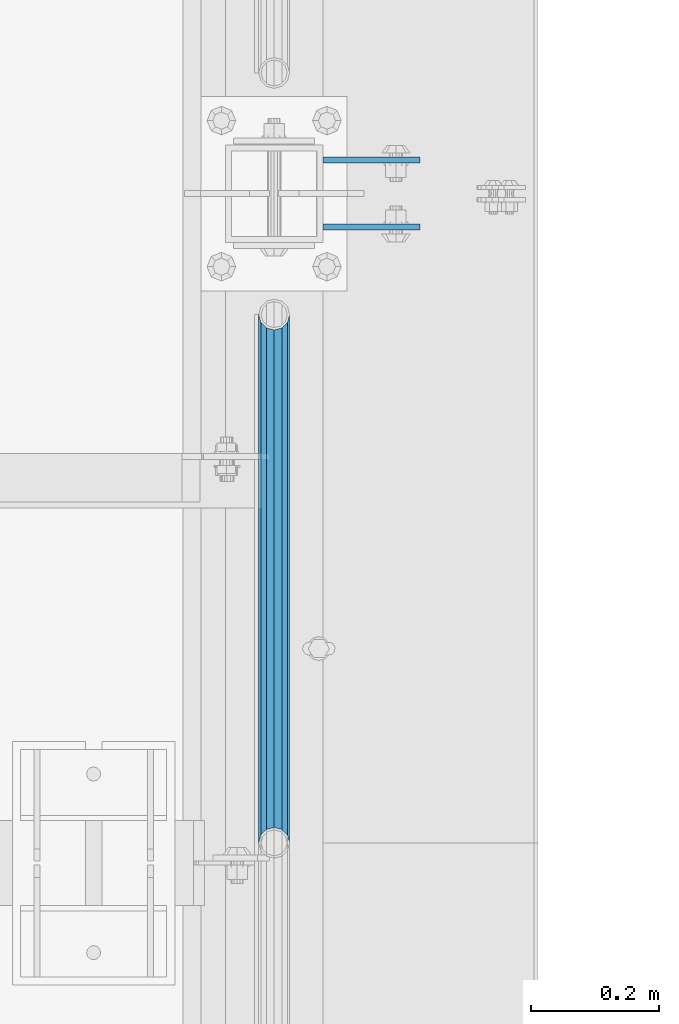
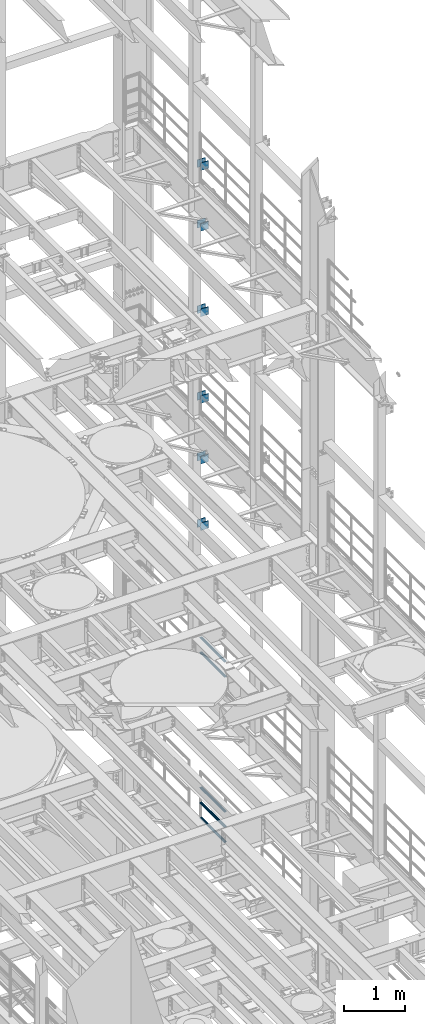
# One storey, part 1348 of 1876: 17 beams, 5 elements without a shape of their own.
"""IFC2X3 building model written with IfcOpenShell, lengths in millimetres."""

import ifcopenshell
import ifcopenshell.guid

model = None  # the IFC model being written
_history = None  # IfcOwnerHistory: only IFC2X3 demands one
_inside = {}  # id of a spatial element -> (the spatial element, [elements in it])
_under = {}  # id of a project, library or spatial element -> (it, [spatial elements below it])
_declared = {}  # id of a project -> (the project, [libraries it declares])
_typed = {}  # id of a type object -> (the type object, [elements of that type])
_made_of = {}  # id of a material, layer set ... -> (it, [elements and type objects made of it])


def new_model(schema):
    """Start an empty IFC model of exactly this schema.

    Asked for "IFC4X3", IfcOpenShell would pick the latest addendum, in which some entities
    have other attributes; the version numbers below select the first issue.
    IFC2X3 requires an IfcOwnerHistory on every rooted entity: one is made here for all.
    """
    global model, _history
    if schema == "IFC4X3":
        model = ifcopenshell.file(schema_version=(4, 3, 0, 0))
    else:
        model = ifcopenshell.file(schema=schema)
    _inside.clear()
    _under.clear()
    _declared.clear()
    _typed.clear()
    _made_of.clear()
    _history = None
    if model.schema == "IFC2X3":
        org = make("IfcOrganization", Name="unknown")
        user = make(
            "IfcPersonAndOrganization",
            ThePerson=make("IfcPerson", FamilyName="unknown"),
            TheOrganization=org,
        )
        app = make(
            "IfcApplication",
            ApplicationDeveloper=org,
            Version="unknown",
            ApplicationFullName="unknown",
            ApplicationIdentifier="unknown",
        )
        _history = make(
            "IfcOwnerHistory",
            OwningUser=user,
            OwningApplication=app,
            ChangeAction="ADDED",
            CreationDate=0,
        )
    return model


def make(cls, **values):
    """One entity of the class cls with the attributes given. An attribute that is None is left unset."""
    return model.create_entity(
        cls, **{name: value for name, value in values.items() if value is not None}
    )


def rooted(cls, **values):
    """An entity with a GlobalId (a new one), such as an element, a storey or a relation."""
    return make(cls, GlobalId=ifcopenshell.guid.new(), OwnerHistory=_history, **values)


def si_unit(unit_type, name, prefix=None):
    """IfcSIUnit, for example si_unit("LENGTHUNIT", "METRE", prefix="MILLI")."""
    return make("IfcSIUnit", UnitType=unit_type, Prefix=prefix, Name=name)


def assignment(units):
    """IfcUnitAssignment: the units of a project."""
    return None if units is None else make("IfcUnitAssignment", Units=units)


def point(xyz):
    """IfcCartesianPoint."""
    return None if xyz is None else make("IfcCartesianPoint", Coordinates=xyz)


def direction(xyz):
    """IfcDirection."""
    return None if xyz is None else make("IfcDirection", DirectionRatios=xyz)


def frame(location, z_axis=None, x_axis=None):
    """IfcAxis2Placement3D, a coordinate frame: its origin and axes. An axis left out is left unset."""
    return make(
        "IfcAxis2Placement3D",
        Location=point(location),
        Axis=direction(z_axis),
        RefDirection=direction(x_axis),
    )


def origin_with_axes():
    """The frame at (0, 0, 0) with the z axis (0, 0, 1) and the x axis (1, 0, 0) written out."""
    return frame((0.0, 0.0, 0.0), z_axis=(0.0, 0.0, 1.0), x_axis=(1.0, 0.0, 0.0))


def place(relative_to, where):
    """IfcLocalPlacement: puts the frame where relative to a parent placement (None: the world)."""
    return make(
        "IfcLocalPlacement", PlacementRelTo=relative_to, RelativePlacement=where
    )


def context(
    kind, dimensions, precision=None, world=None, true_north=None, identifier=None
):
    """IfcGeometricRepresentationContext, for example the 3D "Model" context."""
    return make(
        "IfcGeometricRepresentationContext",
        ContextIdentifier=identifier,
        ContextType=kind,
        CoordinateSpaceDimension=dimensions,
        Precision=precision,
        WorldCoordinateSystem=world,
        TrueNorth=true_north,
    )


def subcontext(parent, identifier, kind, view, scale=None):
    """IfcGeometricRepresentationSubContext, for example "Body" below "Model"."""
    return make(
        "IfcGeometricRepresentationSubContext",
        ContextIdentifier=identifier,
        ContextType=kind,
        ParentContext=parent,
        TargetScale=scale,
        TargetView=view,
    )


def project(units=None, contexts=None):
    """IfcProject with its units and contexts."""
    return rooted(
        "IfcProject",
        Name="project",
        RepresentationContexts=contexts,
        UnitsInContext=assignment(units),
    )


def spatial(cls, under=None, at=None, **own):
    """A site, building, storey or space (cls), placed at a placement, below another one or the project."""
    s = rooted(cls, ObjectPlacement=at, **own)
    if under is not None:
        _under.setdefault(under.id(), (under, []))[1].append(s)
    return s


def faces_of(points, faces, orient=None, outer=None):
    """IfcFace entities. A face is a list of loops; a loop is a list of indices into points, from 0.

    orient and outer hold one flag for each loop. By default every Orientation is true, the
    first loop of a face is its IfcFaceOuterBound and the others are IfcFaceBound.
    """
    made = []
    for i, loops in enumerate(faces):
        bounds = []
        for j, loop in enumerate(loops):
            is_outer = j == 0 if outer is None else outer[i][j]
            bounds.append(
                make(
                    "IfcFaceOuterBound" if is_outer else "IfcFaceBound",
                    Bound=make("IfcPolyLoop", Polygon=[points[k] for k in loop]),
                    Orientation=True if orient is None else orient[i][j],
                )
            )
        made.append(make("IfcFace", Bounds=bounds))
    return made


def faceted_brep(points, faces, orient=None, outer=None, voids=None):
    """IfcFacetedBrep: a solid bounded by flat faces; with voids (closed shells), ...WithVoids."""
    shared = [point(p) for p in points]
    hull = make("IfcClosedShell", CfsFaces=faces_of(shared, faces, orient, outer))
    if voids is None:
        return make("IfcFacetedBrep", Outer=hull)
    return make(
        "IfcFacetedBrepWithVoids",
        Outer=hull,
        Voids=[
            make(cls, CfsFaces=faces_of(shared, fs, o, b)) for cls, fs, o, b in voids
        ],
    )


def shape(context_of_items, identifier, shape_type, items):
    """IfcShapeRepresentation: the items that make up one representation, for example the "Body"."""
    return make(
        "IfcShapeRepresentation",
        ContextOfItems=context_of_items,
        RepresentationIdentifier=identifier,
        RepresentationType=shape_type,
        Items=items,
    )


def material(Name=None, Category=None):
    """IfcMaterial."""
    return make("IfcMaterial", Name=Name, Category=Category)


def made_of(thing, what):
    """Note that an element or type object is made of a material, layer set ...; save() writes the relation."""
    if what is not None:
        _made_of.setdefault(what.id(), (what, []))[1].append(thing)
    return thing


def type_object(cls, material=None, **own):
    """A type object (cls), such as IfcWallType, which elements share."""
    return made_of(rooted(cls, **own), material)


def element(
    cls,
    number,
    at=None,
    inside=None,
    cuts=None,
    type_object=None,
    material=None,
    context=None,
    identifier="Body",
    shape_type=None,
    held_by="IfcProductDefinitionShape",
    body=None,
    shapes=None,
    **own,
):
    """One element of the class cls, such as IfcWall. Its Tag is "e" and its number.

    at: its placement. inside: the storey or other place that contains it. cuts: it is an
    opening in that element (IfcRelVoidsElement). A single representation is given by context,
    identifier, shape_type and body (its items); several are given by shapes. held_by: the class
    of the entity that holds the representations. save() writes the other relations.
    """
    e = rooted(cls, Tag="e%d" % number, ObjectPlacement=at, **own)
    if body is not None:
        shapes = [shape(context, identifier, shape_type, body)]
    if shapes is not None:
        e.Representation = make(held_by, Representations=shapes)
    if inside is not None:
        _inside.setdefault(inside.id(), (inside, []))[1].append(e)
    if cuts is not None:
        rooted(
            "IfcRelVoidsElement", RelatingBuildingElement=cuts, RelatedOpeningElement=e
        )
    if type_object is not None:
        _typed.setdefault(type_object.id(), (type_object, []))[1].append(e)
    return made_of(e, material)


def aggregate(whole, parts):
    """IfcRelAggregates: a whole, such as a stair, and the parts it consists of."""
    return rooted("IfcRelAggregates", RelatingObject=whole, RelatedObjects=parts)


def save(model, path):
    """Write the relations noted so far, then the file.

    IfcRelAggregates (storeys below a building ...), IfcRelContainedInSpatialStructure (elements
    in a storey), IfcRelDefinesByType, IfcRelAssociatesMaterial and IfcRelDeclares: one each for
    every whole, place, type object, material and project.
    """
    for whole, parts in _under.values():
        aggregate(whole, parts)
    for where, things in _inside.values():
        rooted(
            "IfcRelContainedInSpatialStructure",
            RelatedElements=things,
            RelatingStructure=where,
        )
    for kind, things in _typed.values():
        rooted("IfcRelDefinesByType", RelatedObjects=things, RelatingType=kind)
    for what, things in _made_of.values():
        rooted("IfcRelAssociatesMaterial", RelatedObjects=things, RelatingMaterial=what)
    for by, libraries in _declared.values():
        rooted("IfcRelDeclares", RelatingContext=by, RelatedDefinitions=libraries)
    model.write(path)


model = new_model("IFC2X3")

# Units and contexts
model_context = context("Model", 3, precision=1e-05, world=origin_with_axes())
body_context = subcontext(model_context, "Body", "Model", "MODEL_VIEW")
ifc_project = project(units=[si_unit("LENGTHUNIT", "METRE", prefix="MILLI"), si_unit("AREAUNIT", "SQUARE_METRE"), si_unit("VOLUMEUNIT", "CUBIC_METRE"), si_unit("MASSUNIT", "GRAM", prefix="KILO"), si_unit("TIMEUNIT", "SECOND"), si_unit("PLANEANGLEUNIT", "RADIAN"), si_unit("SOLIDANGLEUNIT", "STERADIAN"), si_unit("THERMODYNAMICTEMPERATUREUNIT", "DEGREE_CELSIUS"), si_unit("LUMINOUSINTENSITYUNIT", "LUMEN")], contexts=[model_context])

# Site, building, storey
site_placement = place(None, origin_with_axes())
site = spatial("IfcSite", under=ifc_project, at=site_placement, CompositionType="ELEMENT")
building_placement = place(site_placement, origin_with_axes())
building = spatial("IfcBuilding", under=site, at=building_placement, Name="Undefined", CompositionType="ELEMENT")
storey_placement = place(building_placement, origin_with_axes())
storey = spatial("IfcBuildingStorey", under=building, at=storey_placement, Name="Undefined", CompositionType="ELEMENT", Elevation=0.0)

# Assembly, beams
assembly_1_placement = place(storey_placement, origin_with_axes())
assembly_1 = element("IfcElementAssembly", 1, at=assembly_1_placement, inside=storey, Name="BEAM", AssemblyPlace="NOTDEFINED", PredefinedType="RIGID_FRAME")
ifc_material_1 = material(Name="STEEL/A36")
beam_type_1 = type_object("IfcBeamType", PredefinedType="NOTDEFINED")
beam_1_placement = place(assembly_1_placement, frame((7696.2, 11736.3875, 12369.8), z_axis=(0.0, 0.0, -1.0), x_axis=(1.0, 0.0, 0.0)))
beam_1 = element("IfcBeam", 2, at=beam_1_placement, type_object=beam_type_1, material=ifc_material_1, Name="PLATE", context=body_context, shape_type="Brep", body=[
    faceted_brep([(0.0, 4.76249999999982, -76.1999999999998), (3.63797880709171e-12, 4.76249999999982, 76.1999969482422), (152.399993896484, 4.76250000000073, 76.1999969482422), (152.4, 4.76249999999982, -76.1999999999998), (3.63797880709171e-12, -4.76249999999982, 76.1999969482422), (152.399993896484, -4.76250000000073, 76.1999969482422), (0.0, -4.76249999999982, -76.1999999999998), (152.4, -4.76249999999982, -76.1999999999998)], [[[0, 1, 2, 3]], [[4, 5, 2, 1]], [[4, 6, 7, 5]], [[6, 0, 3, 7]], [[5, 7, 3, 2]], [[6, 4, 1, 0]]]),
])
beam_2_placement = place(assembly_1_placement, frame((7696.2, 11631.6125, 12369.8), z_axis=(0.0, 0.0, -1.0), x_axis=(1.0, 0.0, 0.0)))
beam_2 = element("IfcBeam", 3, at=beam_2_placement, type_object=beam_type_1, material=ifc_material_1, Name="PLATE", context=body_context, shape_type="Brep", body=[
    faceted_brep([(0.0, 4.76249999999982, -76.1999999999998), (3.63797880709171e-12, 4.76249999999982, 76.1999969482422), (152.399993896484, 4.76250000000073, 76.1999969482422), (152.4, 4.76249999999982, -76.1999999999998), (3.63797880709171e-12, -4.76249999999982, 76.1999969482422), (152.399993896484, -4.76250000000073, 76.1999969482422), (0.0, -4.76249999999982, -76.1999999999998), (152.4, -4.76249999999982, -76.1999999999998)], [[[0, 1, 2, 3]], [[4, 5, 2, 1]], [[4, 6, 7, 5]], [[6, 0, 3, 7]], [[5, 7, 3, 2]], [[6, 4, 1, 0]]]),
])
beam_3_placement = place(assembly_1_placement, frame((7696.2, 11736.3875, 11029.95), z_axis=(0.0, 0.0, -1.0), x_axis=(1.0, 0.0, 0.0)))
beam_3 = element("IfcBeam", 4, at=beam_3_placement, type_object=beam_type_1, material=ifc_material_1, Name="PLATE", context=body_context, shape_type="Brep", body=[
    faceted_brep([(0.0, 4.76249999999982, -76.1999999999998), (3.63797880709171e-12, 4.76249999999982, 76.1999969482422), (152.399993896484, 4.76250000000073, 76.1999969482422), (152.4, 4.76249999999982, -76.1999999999998), (3.63797880709171e-12, -4.76249999999982, 76.1999969482422), (152.399993896484, -4.76250000000073, 76.1999969482422), (0.0, -4.76249999999982, -76.1999999999998), (152.4, -4.76249999999982, -76.1999999999998)], [[[0, 1, 2, 3]], [[4, 5, 2, 1]], [[4, 6, 7, 5]], [[6, 0, 3, 7]], [[5, 7, 3, 2]], [[6, 4, 1, 0]]]),
])
beam_4_placement = place(assembly_1_placement, frame((7696.2, 11631.6125, 11029.95), z_axis=(0.0, 0.0, -1.0), x_axis=(1.0, 0.0, 0.0)))
beam_4 = element("IfcBeam", 5, at=beam_4_placement, type_object=beam_type_1, material=ifc_material_1, Name="PLATE", context=body_context, shape_type="Brep", body=[
    faceted_brep([(0.0, 4.76249999999982, -76.1999999999998), (3.63797880709171e-12, 4.76249999999982, 76.1999969482422), (152.399993896484, 4.76250000000073, 76.1999969482422), (152.4, 4.76249999999982, -76.1999999999998), (3.63797880709171e-12, -4.76249999999982, 76.1999969482422), (152.399993896484, -4.76250000000073, 76.1999969482422), (0.0, -4.76249999999982, -76.1999999999998), (152.4, -4.76249999999982, -76.1999999999998)], [[[0, 1, 2, 3]], [[4, 5, 2, 1]], [[4, 6, 7, 5]], [[6, 0, 3, 7]], [[5, 7, 3, 2]], [[6, 4, 1, 0]]]),
])
aggregate(assembly_1, [beam_1, beam_2, beam_3, beam_4])

assembly_2_placement = place(storey_placement, origin_with_axes())
assembly_2 = element("IfcElementAssembly", 6, at=assembly_2_placement, inside=storey, Name="BEAM", AssemblyPlace="NOTDEFINED", PredefinedType="RIGID_FRAME")
beam_5_placement = place(assembly_2_placement, frame((7696.2, 11736.3875, 13589.0), z_axis=(0.0, 0.0, -1.0), x_axis=(1.0, 0.0, 0.0)))
beam_5 = element("IfcBeam", 7, at=beam_5_placement, type_object=beam_type_1, material=ifc_material_1, Name="PLATE", context=body_context, shape_type="Brep", body=[
    faceted_brep([(0.0, 4.76249999999982, -76.1999999999998), (3.63797880709171e-12, 4.76249999999982, 76.1999969482422), (152.399993896484, 4.76250000000073, 76.1999969482422), (152.4, 4.76249999999982, -76.1999999999998), (3.63797880709171e-12, -4.76249999999982, 76.1999969482422), (152.399993896484, -4.76250000000073, 76.1999969482422), (0.0, -4.76249999999982, -76.1999999999998), (152.4, -4.76249999999982, -76.1999999999998)], [[[0, 1, 2, 3]], [[4, 5, 2, 1]], [[4, 6, 7, 5]], [[6, 0, 3, 7]], [[5, 7, 3, 2]], [[6, 4, 1, 0]]]),
])
beam_6_placement = place(assembly_2_placement, frame((7696.2, 11631.6125, 13589.0), z_axis=(0.0, 0.0, -1.0), x_axis=(1.0, 0.0, 0.0)))
beam_6 = element("IfcBeam", 8, at=beam_6_placement, type_object=beam_type_1, material=ifc_material_1, Name="PLATE", context=body_context, shape_type="Brep", body=[
    faceted_brep([(0.0, 4.76249999999982, -76.1999999999998), (3.63797880709171e-12, 4.76249999999982, 76.1999969482422), (152.399993896484, 4.76250000000073, 76.1999969482422), (152.4, 4.76249999999982, -76.1999999999998), (3.63797880709171e-12, -4.76249999999982, 76.1999969482422), (152.399993896484, -4.76250000000073, 76.1999969482422), (0.0, -4.76249999999982, -76.1999999999998), (152.4, -4.76249999999982, -76.1999999999998)], [[[0, 1, 2, 3]], [[4, 5, 2, 1]], [[4, 6, 7, 5]], [[6, 0, 3, 7]], [[5, 7, 3, 2]], [[6, 4, 1, 0]]]),
])
beam_7_placement = place(assembly_2_placement, frame((7696.2, 11736.3875, 17056.1), z_axis=(0.0, 0.0, -1.0), x_axis=(1.0, 0.0, 0.0)))
beam_7 = element("IfcBeam", 9, at=beam_7_placement, type_object=beam_type_1, material=ifc_material_1, Name="PLATE", context=body_context, shape_type="Brep", body=[
    faceted_brep([(0.0, 4.76249999999982, -76.1999999999998), (3.63797880709171e-12, 4.76249999999982, 76.1999969482422), (152.399993896484, 4.76250000000073, 76.1999969482422), (152.4, 4.76249999999982, -76.1999999999998), (3.63797880709171e-12, -4.76249999999982, 76.1999969482422), (152.399993896484, -4.76250000000073, 76.1999969482422), (0.0, -4.76249999999982, -76.1999999999998), (152.4, -4.76249999999982, -76.1999999999998)], [[[0, 1, 2, 3]], [[4, 5, 2, 1]], [[4, 6, 7, 5]], [[6, 0, 3, 7]], [[5, 7, 3, 2]], [[6, 4, 1, 0]]]),
])
beam_8_placement = place(assembly_2_placement, frame((7696.2, 11631.6125, 17056.1), z_axis=(0.0, 0.0, -1.0), x_axis=(1.0, 0.0, 0.0)))
beam_8 = element("IfcBeam", 10, at=beam_8_placement, type_object=beam_type_1, material=ifc_material_1, Name="PLATE", context=body_context, shape_type="Brep", body=[
    faceted_brep([(0.0, 4.76249999999982, -76.1999999999998), (3.63797880709171e-12, 4.76249999999982, 76.1999969482422), (152.399993896484, 4.76250000000073, 76.1999969482422), (152.4, 4.76249999999982, -76.1999999999998), (3.63797880709171e-12, -4.76249999999982, 76.1999969482422), (152.399993896484, -4.76250000000073, 76.1999969482422), (0.0, -4.76249999999982, -76.1999999999998), (152.4, -4.76249999999982, -76.1999999999998)], [[[0, 1, 2, 3]], [[4, 5, 2, 1]], [[4, 6, 7, 5]], [[6, 0, 3, 7]], [[5, 7, 3, 2]], [[6, 4, 1, 0]]]),
])
beam_9_placement = place(assembly_2_placement, frame((7696.2, 11736.3875, 15335.25), z_axis=(0.0, 0.0, -1.0), x_axis=(1.0, 0.0, 0.0)))
beam_9 = element("IfcBeam", 11, at=beam_9_placement, type_object=beam_type_1, material=ifc_material_1, Name="PLATE", context=body_context, shape_type="Brep", body=[
    faceted_brep([(0.0, 4.76249999999982, -76.1999999999998), (3.63797880709171e-12, 4.76249999999982, 76.1999969482422), (152.399993896484, 4.76250000000073, 76.1999969482422), (152.4, 4.76249999999982, -76.1999999999998), (3.63797880709171e-12, -4.76249999999982, 76.1999969482422), (152.399993896484, -4.76250000000073, 76.1999969482422), (0.0, -4.76249999999982, -76.1999999999998), (152.4, -4.76249999999982, -76.1999999999998)], [[[0, 1, 2, 3]], [[4, 5, 2, 1]], [[4, 6, 7, 5]], [[6, 0, 3, 7]], [[5, 7, 3, 2]], [[6, 4, 1, 0]]]),
])
beam_10_placement = place(assembly_2_placement, frame((7696.2, 11631.6125, 15335.25), z_axis=(0.0, 0.0, -1.0), x_axis=(1.0, 0.0, 0.0)))
beam_10 = element("IfcBeam", 12, at=beam_10_placement, type_object=beam_type_1, material=ifc_material_1, Name="PLATE", context=body_context, shape_type="Brep", body=[
    faceted_brep([(0.0, 4.76249999999982, -76.1999999999998), (3.63797880709171e-12, 4.76249999999982, 76.1999969482422), (152.399993896484, 4.76250000000073, 76.1999969482422), (152.4, 4.76249999999982, -76.1999999999998), (3.63797880709171e-12, -4.76249999999982, 76.1999969482422), (152.399993896484, -4.76250000000073, 76.1999969482422), (0.0, -4.76249999999982, -76.1999999999998), (152.4, -4.76249999999982, -76.1999999999998)], [[[0, 1, 2, 3]], [[4, 5, 2, 1]], [[4, 6, 7, 5]], [[6, 0, 3, 7]], [[5, 7, 3, 2]], [[6, 4, 1, 0]]]),
])
aggregate(assembly_2, [beam_5, beam_6, beam_7, beam_8, beam_9, beam_10])

assembly_3_placement = place(storey_placement, origin_with_axes())
assembly_3 = element("IfcElementAssembly", 13, at=assembly_3_placement, inside=storey, Name="BEAM", AssemblyPlace="NOTDEFINED", PredefinedType="RIGID_FRAME")
beam_11_placement = place(assembly_3_placement, frame((7696.20000025489, 11736.3875, 18275.3), z_axis=(0.0, 0.0, -1.0), x_axis=(1.0, 0.0, 0.0)))
beam_11 = element("IfcBeam", 14, at=beam_11_placement, type_object=beam_type_1, material=ifc_material_1, Name="PLATE", context=body_context, shape_type="Brep", body=[
    faceted_brep([(0.0, 4.76249999999982, -76.1999999999998), (3.63797880709171e-12, 4.76249999999982, 76.1999969482422), (152.399993896484, 4.76250000000073, 76.1999969482422), (152.4, 4.76249999999982, -76.1999999999998), (3.63797880709171e-12, -4.76249999999982, 76.1999969482422), (152.399993896484, -4.76250000000073, 76.1999969482422), (0.0, -4.76249999999982, -76.1999999999998), (152.4, -4.76249999999982, -76.1999999999998)], [[[0, 1, 2, 3]], [[4, 5, 2, 1]], [[4, 6, 7, 5]], [[6, 0, 3, 7]], [[5, 7, 3, 2]], [[6, 4, 1, 0]]]),
])
beam_12_placement = place(assembly_3_placement, frame((7696.20000025489, 11631.6125, 18275.3), z_axis=(0.0, 0.0, -1.0), x_axis=(1.0, 0.0, 0.0)))
beam_12 = element("IfcBeam", 15, at=beam_12_placement, type_object=beam_type_1, material=ifc_material_1, Name="PLATE", context=body_context, shape_type="Brep", body=[
    faceted_brep([(0.0, 4.76249999999982, -76.1999999999998), (3.63797880709171e-12, 4.76249999999982, 76.1999969482422), (152.399993896484, 4.76250000000073, 76.1999969482422), (152.4, 4.76249999999982, -76.1999999999998), (3.63797880709171e-12, -4.76249999999982, 76.1999969482422), (152.399993896484, -4.76250000000073, 76.1999969482422), (0.0, -4.76249999999982, -76.1999999999998), (152.4, -4.76249999999982, -76.1999999999998)], [[[0, 1, 2, 3]], [[4, 5, 2, 1]], [[4, 6, 7, 5]], [[6, 0, 3, 7]], [[5, 7, 3, 2]], [[6, 4, 1, 0]]]),
])
aggregate(assembly_3, [beam_11, beam_12])

assembly_4_placement = place(storey_placement, origin_with_axes())
assembly_4 = element("IfcElementAssembly", 16, at=assembly_4_placement, inside=storey, Name="RAIL", AssemblyPlace="NOTDEFINED", PredefinedType="RIGID_FRAME")
ifc_material_2 = material()
beam_type_2 = type_object("IfcBeamType", Name="PIPE1-1/2SCH40", PredefinedType="NOTDEFINED")
beam_13_placement = place(assembly_4_placement, frame((7620.0, 10668.0, 8620.125), z_axis=(0.0, 0.0, -1.0), x_axis=(0.0, 1.0, 0.0)))
beam_13 = element("IfcBeam", 17, at=beam_13_placement, type_object=beam_type_2, material=ifc_material_2, Name="RAIL", ObjectType="PIPE1-1/2SCH40", context=body_context, shape_type="Brep", body=[
    faceted_brep([(0.0, 24.1299999999992, 0.0), (12.0650000000064, 20.8971929933177, -12.0649999999987), (12.0650000000064, 20.8971929933177, 12.0649999999987), (12.0650000000064, -20.8971929933177, 12.0649999999987), (12.0650000000064, -20.8971929933177, -12.0649999999987), (0.0, -24.1299999999992, 0.0), (20.8971929933249, -12.0650000000005, 20.8971929933177), (20.8971929933249, -12.0650000000005, 15.8661214311796), (15.2545715621445, -17.7076214311801, 10.2235000000001), (12.5151929933249, -20.4470000000001, 0.0), (15.2545715621445, -17.7076214311801, -10.2235000000001), (20.8971929933249, -12.0650000000005, -15.8661214311796), (20.8971929933249, -12.0650000000005, -20.8971929933177), (24.1300000000063, 0.0, -20.4470000000001), (24.1300000000063, 0.0, -24.130000000001), (21.3906214311868, -10.2235000000001, -17.7076214311819), (21.3906214311868, 10.2235000000001, -17.7076214311819), (20.8971929933249, 12.0650000000005, -15.8661214311796), (20.8971929933249, 12.0650000000005, -20.8971929933177), (15.2545715621445, 17.7076214311801, -10.2235000000001), (12.5151929933249, 20.4470000000001, 0.0), (15.2545715621445, 17.7076214311801, 10.2235000000001), (20.8971929933249, 12.0650000000005, 15.8661214311796), (20.8971929933249, 12.0650000000005, 20.8971929933177), (21.3906214311868, 10.2235000000001, 17.7076214311819), (24.1300000000064, 0.0, 20.4470000000001), (24.1300000000064, 0.0, 24.130000000001), (21.3906214311868, -10.2235000000001, 17.7076214311819), (826.77, 24.1300000000001, 0.0), (814.705, 20.8971929933186, -12.0649999999987), (805.872807006681, 12.0649999999996, -20.8971929933177), (826.77, -24.1300000000001, 0.0), (814.705, -20.8971929933186, -12.0649999999987), (814.705, -20.8971929933186, 12.0649999999987), (805.872807006681, -12.0649999999996, 20.8971929933177), (805.872807006681, -12.0649999999996, -20.8971929933177), (802.640000000001, 0.0, -24.130000000001), (805.379378568819, 10.2235000000001, -17.7076214311819), (802.640000000001, 0.0, -20.4470000000001), (805.872807006683, 12.0649999999996, -15.8661214311796), (805.872807006683, -12.0649999999996, -15.8661214311796), (805.379378568819, -10.2235000000001, -17.7076214311819), (811.515428437862, -17.7076214311801, -10.2235000000001), (814.254807006682, -20.4470000000001, 0.0), (811.515428437862, -17.7076214311801, 10.2235000000001), (805.872807006683, -12.0649999999996, 15.8661214311796), (805.379378568819, -10.2235000000001, 17.7076214311819), (802.640000000001, 0.0, 20.4470000000001), (802.640000000001, 0.0, 24.130000000001), (805.872807006681, 12.0649999999996, 20.8971929933177), (814.705, 20.8971929933186, 12.0649999999987), (805.872807006683, 12.0649999999996, 15.8661214311796), (811.515428437862, 17.7076214311801, 10.2235000000001), (814.254807006682, 20.4470000000001, 0.0), (811.515428437862, 17.7076214311801, -10.2235000000001), (805.379378568819, 10.2235000000001, 17.7076214311819)], [[[0, 1, 2]], [[3, 4, 5]], [[6, 7, 8, 9, 10, 11, 12, 4, 3]], [[13, 14, 12, 11, 15]], [[16, 17, 18, 14, 13]], [[2, 1, 18, 17, 19, 20, 21, 22, 23]], [[23, 22, 24, 25, 26]], [[26, 25, 27, 7, 6]], [[1, 0, 28, 29]], [[18, 1, 29, 30]], [[31, 32, 33]], [[6, 3, 33, 34]], [[3, 5, 31, 33]], [[5, 4, 32, 31]], [[4, 12, 35, 32]], [[12, 14, 36, 35]], [[14, 18, 30, 36]], [[37, 38, 36, 30, 39]], [[40, 35, 36, 38, 41]], [[33, 32, 35, 40, 42, 43, 44, 45, 34]], [[34, 45, 46, 47, 48]], [[26, 6, 34, 48]], [[2, 23, 49, 50]], [[23, 26, 48, 49]], [[0, 2, 50, 28]], [[28, 50, 29]], [[49, 51, 52, 53, 54, 39, 30, 29, 50]], [[48, 47, 55, 51, 49]], [[25, 24, 55, 47]], [[55, 24, 22, 21, 52, 51]], [[21, 20, 53, 52]], [[20, 19, 54, 53]], [[19, 17, 16, 37, 39, 54]], [[16, 13, 38, 37]], [[13, 15, 41, 38]], [[41, 15, 11, 10, 42, 40]], [[10, 9, 43, 42]], [[9, 8, 44, 43]], [[8, 7, 27, 46, 45, 44]], [[27, 25, 47, 46]]]),
])
beam_14_placement = place(assembly_4_placement, frame((7620.0, 10668.0, 8924.925), z_axis=(0.0, 0.0, -1.0), x_axis=(0.0, 1.0, 0.0)))
beam_14 = element("IfcBeam", 18, at=beam_14_placement, type_object=beam_type_2, material=ifc_material_2, Name="RAIL", ObjectType="PIPE1-1/2SCH40", context=body_context, shape_type="Brep", body=[
    faceted_brep([(0.0, 24.1299999999992, 0.0), (12.0650000000064, 20.8971929933177, -12.0649999999987), (12.0650000000064, 20.8971929933177, 12.0649999999987), (12.0650000000064, -20.8971929933177, 12.0649999999987), (12.0650000000064, -20.8971929933177, -12.0649999999987), (0.0, -24.1299999999992, 0.0), (20.8971929933249, -12.0650000000005, 20.8971929933177), (20.8971929933249, -12.0650000000005, 15.8661214311796), (15.2545715621445, -17.7076214311801, 10.2235000000001), (12.5151929933249, -20.4470000000001, 0.0), (15.2545715621445, -17.7076214311801, -10.2235000000001), (20.8971929933249, -12.0650000000005, -15.8661214311796), (20.8971929933249, -12.0650000000005, -20.8971929933177), (24.1300000000063, 0.0, -20.4470000000001), (24.1300000000063, 0.0, -24.130000000001), (21.3906214311868, -10.2235000000001, -17.7076214311819), (21.3906214311868, 10.2235000000001, -17.7076214311819), (20.8971929933249, 12.0650000000005, -15.8661214311796), (20.8971929933249, 12.0650000000005, -20.8971929933177), (15.2545715621445, 17.7076214311801, -10.2235000000001), (12.5151929933249, 20.4470000000001, 0.0), (15.2545715621445, 17.7076214311801, 10.2235000000001), (20.8971929933249, 12.0650000000005, 15.8661214311796), (20.8971929933249, 12.0650000000005, 20.8971929933177), (21.3906214311868, 10.2235000000001, 17.7076214311819), (24.1300000000064, 0.0, 20.4470000000001), (24.1300000000064, 0.0, 24.130000000001), (21.3906214311868, -10.2235000000001, 17.7076214311819), (826.77, 24.1300000000001, 0.0), (814.705, 20.8971929933186, -12.0649999999987), (805.872807006681, 12.0649999999996, -20.8971929933177), (826.77, -24.1300000000001, 0.0), (814.705, -20.8971929933186, -12.0649999999987), (814.705, -20.8971929933186, 12.0649999999987), (805.872807006681, -12.0649999999996, 20.8971929933177), (805.872807006681, -12.0649999999996, -20.8971929933177), (802.640000000001, 0.0, -24.130000000001), (805.379378568819, 10.2235000000001, -17.7076214311819), (802.640000000001, 0.0, -20.4470000000001), (805.872807006683, 12.0649999999996, -15.8661214311796), (805.872807006683, -12.0649999999996, -15.8661214311796), (805.379378568819, -10.2235000000001, -17.7076214311819), (811.515428437862, -17.7076214311801, -10.2235000000001), (814.254807006682, -20.4470000000001, 0.0), (811.515428437862, -17.7076214311801, 10.2235000000001), (805.872807006683, -12.0649999999996, 15.8661214311796), (805.379378568819, -10.2235000000001, 17.7076214311819), (802.640000000001, 0.0, 20.4470000000001), (802.640000000001, 0.0, 24.130000000001), (805.872807006681, 12.0649999999996, 20.8971929933177), (814.705, 20.8971929933186, 12.0649999999987), (805.872807006683, 12.0649999999996, 15.8661214311796), (811.515428437862, 17.7076214311801, 10.2235000000001), (814.254807006682, 20.4470000000001, 0.0), (811.515428437862, 17.7076214311801, -10.2235000000001), (805.379378568819, 10.2235000000001, 17.7076214311819)], [[[0, 1, 2]], [[3, 4, 5]], [[6, 7, 8, 9, 10, 11, 12, 4, 3]], [[13, 14, 12, 11, 15]], [[16, 17, 18, 14, 13]], [[2, 1, 18, 17, 19, 20, 21, 22, 23]], [[23, 22, 24, 25, 26]], [[26, 25, 27, 7, 6]], [[1, 0, 28, 29]], [[18, 1, 29, 30]], [[31, 32, 33]], [[6, 3, 33, 34]], [[3, 5, 31, 33]], [[5, 4, 32, 31]], [[4, 12, 35, 32]], [[12, 14, 36, 35]], [[14, 18, 30, 36]], [[37, 38, 36, 30, 39]], [[40, 35, 36, 38, 41]], [[33, 32, 35, 40, 42, 43, 44, 45, 34]], [[34, 45, 46, 47, 48]], [[26, 6, 34, 48]], [[2, 23, 49, 50]], [[23, 26, 48, 49]], [[0, 2, 50, 28]], [[28, 50, 29]], [[49, 51, 52, 53, 54, 39, 30, 29, 50]], [[48, 47, 55, 51, 49]], [[25, 24, 55, 47]], [[55, 24, 22, 21, 52, 51]], [[21, 20, 53, 52]], [[20, 19, 54, 53]], [[19, 17, 16, 37, 39, 54]], [[16, 13, 38, 37]], [[13, 15, 41, 38]], [[41, 15, 11, 10, 42, 40]], [[10, 9, 43, 42]], [[9, 8, 44, 43]], [[8, 7, 27, 46, 45, 44]], [[27, 25, 47, 46]]]),
])
aggregate(assembly_4, [beam_13, beam_14])

assembly_5_placement = place(storey_placement, origin_with_axes())
assembly_5 = element("IfcElementAssembly", 19, at=assembly_5_placement, inside=storey, Name="RAIL", AssemblyPlace="NOTDEFINED", PredefinedType="RIGID_FRAME")
beam_15_placement = place(assembly_5_placement, frame((7620.0, 11494.77, 5292.725), z_axis=(0.0, 0.0, 1.0), x_axis=(0.0, -1.0, 0.0)))
beam_15 = element("IfcBeam", 20, at=beam_15_placement, type_object=beam_type_2, material=ifc_material_2, Name="RAIL", ObjectType="PIPE1-1/2SCH40", context=body_context, shape_type="Brep", body=[
    faceted_brep([(805.872807006681, -12.0649999999996, 20.8971929933177), (805.872807006683, -12.0649999999996, 15.8661214311796), (805.379378568819, -10.2235000000001, 17.7076214311819), (802.640000000001, 0.0, 20.4470000000001), (802.640000000001, 0.0, 24.130000000001), (805.379378568819, 10.2235000000001, 17.7076214311819), (805.872807006683, 12.0649999999996, 15.8661214311796), (805.872807006681, 12.0649999999996, 20.8971929933177), (826.77, 24.1300000000001, 0.0), (814.705, 20.8971929933186, 12.0649999999987), (814.705, 20.8971929933186, -12.0649999999987), (811.515428437862, 17.7076214311801, 10.2235000000001), (814.254807006682, 20.4470000000001, 0.0), (811.515428437862, 17.7076214311801, -10.2235000000001), (805.872807006683, 12.0649999999996, -15.8661214311796), (805.872807006681, 12.0649999999996, -20.8971929933177), (805.379378568819, 10.2235000000001, -17.7076214311819), (802.640000000001, 0.0, -20.4470000000001), (802.640000000001, 0.0, -24.130000000001), (805.872807006683, -12.0649999999996, -15.8661214311796), (805.872807006681, -12.0649999999996, -20.8971929933177), (805.379378568819, -10.2235000000001, -17.7076214311819), (826.77, -24.1300000000001, 0.0), (814.705, -20.8971929933186, -12.0649999999987), (814.705, -20.8971929933186, 12.0649999999987), (811.515428437862, -17.7076214311801, -10.2235000000001), (814.254807006682, -20.4470000000001, 0.0), (811.515428437862, -17.7076214311801, 10.2235000000001), (12.0650000000064, -20.8971929933177, -12.0649999999987), (20.8971929933249, -12.0650000000005, -20.8971929933177), (0.0, 24.1299999999992, 0.0), (12.0650000000064, 20.8971929933177, -12.0649999999987), (12.0650000000064, 20.8971929933177, 12.0649999999987), (20.8971929933249, 12.0650000000005, 20.8971929933177), (24.1300000000064, 0.0, 24.130000000001), (20.8971929933249, 12.0650000000005, -20.8971929933177), (24.1300000000063, 0.0, -24.130000000001), (24.1300000000063, 0.0, -20.4470000000001), (20.8971929933249, -12.0650000000005, -15.8661214311796), (21.3906214311868, -10.2235000000001, -17.7076214311819), (21.3906214311868, 10.2235000000001, -17.7076214311819), (20.8971929933249, 12.0650000000005, -15.8661214311796), (15.2545715621445, 17.7076214311801, -10.2235000000001), (12.5151929933249, 20.4470000000001, 0.0), (15.2545715621445, 17.7076214311801, 10.2235000000001), (20.8971929933249, 12.0650000000005, 15.8661214311796), (21.3906214311868, 10.2235000000001, 17.7076214311819), (24.1300000000064, 0.0, 20.4470000000001), (21.3906214311868, -10.2235000000001, 17.7076214311819), (20.8971929933249, -12.0650000000005, 15.8661214311796), (20.8971929933249, -12.0650000000005, 20.8971929933177), (12.0650000000064, -20.8971929933177, 12.0649999999987), (0.0, -24.1299999999992, 0.0), (15.2545715621445, -17.7076214311801, 10.2235000000001), (12.5151929933249, -20.4470000000001, 0.0), (15.2545715621445, -17.7076214311801, -10.2235000000001)], [[[0, 1, 2, 3, 4]], [[4, 3, 5, 6, 7]], [[8, 9, 10]], [[7, 6, 11, 12, 13, 14, 15, 10, 9]], [[16, 17, 18, 15, 14]], [[19, 20, 18, 17, 21]], [[22, 23, 24]], [[24, 23, 20, 19, 25, 26, 27, 1, 0]], [[28, 29, 20, 23]], [[30, 31, 32]], [[33, 34, 4, 7]], [[32, 33, 7, 9]], [[30, 32, 9, 8]], [[31, 30, 8, 10]], [[35, 31, 10, 15]], [[36, 35, 15, 18]], [[29, 36, 18, 20]], [[37, 36, 29, 38, 39]], [[40, 41, 35, 36, 37]], [[32, 31, 35, 41, 42, 43, 44, 45, 33]], [[33, 45, 46, 47, 34]], [[34, 47, 48, 49, 50]], [[34, 50, 0, 4]], [[50, 51, 24, 0]], [[51, 52, 22, 24]], [[52, 28, 23, 22]], [[51, 28, 52]], [[50, 49, 53, 54, 55, 38, 29, 28, 51]], [[55, 54, 26, 25]], [[21, 39, 38, 55, 25, 19]], [[37, 39, 21, 17]], [[40, 37, 17, 16]], [[42, 41, 40, 16, 14, 13]], [[43, 42, 13, 12]], [[44, 43, 12, 11]], [[5, 46, 45, 44, 11, 6]], [[47, 46, 5, 3]], [[48, 47, 3, 2]], [[53, 49, 48, 2, 1, 27]], [[54, 53, 27, 26]]]),
])
beam_16_placement = place(assembly_5_placement, frame((7620.0, 10668.0, 5597.525), z_axis=(0.0, 0.0, -1.0), x_axis=(0.0, 1.0, 0.0)))
beam_16 = element("IfcBeam", 21, at=beam_16_placement, type_object=beam_type_2, material=ifc_material_2, Name="RAIL", ObjectType="PIPE1-1/2SCH40", context=body_context, shape_type="Brep", body=[
    faceted_brep([(0.0, 24.1299999999992, 0.0), (12.0650000000064, 20.8971929933177, -12.0649999999987), (12.0650000000064, 20.8971929933177, 12.0649999999987), (12.0650000000064, -20.8971929933177, 12.0649999999987), (12.0650000000064, -20.8971929933177, -12.0649999999987), (0.0, -24.1299999999992, 0.0), (20.8971929933249, -12.0650000000005, 20.8971929933177), (20.8971929933249, -12.0650000000005, 15.8661214311796), (15.2545715621445, -17.7076214311801, 10.2235000000001), (12.5151929933249, -20.4470000000001, 0.0), (15.2545715621445, -17.7076214311801, -10.2235000000001), (20.8971929933249, -12.0650000000005, -15.8661214311796), (20.8971929933249, -12.0650000000005, -20.8971929933177), (24.1300000000063, 0.0, -20.4470000000001), (24.1300000000063, 0.0, -24.130000000001), (21.3906214311868, -10.2235000000001, -17.7076214311819), (21.3906214311868, 10.2235000000001, -17.7076214311819), (20.8971929933249, 12.0650000000005, -15.8661214311796), (20.8971929933249, 12.0650000000005, -20.8971929933177), (15.2545715621445, 17.7076214311801, -10.2235000000001), (12.5151929933249, 20.4470000000001, 0.0), (15.2545715621445, 17.7076214311801, 10.2235000000001), (20.8971929933249, 12.0650000000005, 15.8661214311796), (20.8971929933249, 12.0650000000005, 20.8971929933177), (21.3906214311868, 10.2235000000001, 17.7076214311819), (24.1300000000064, 0.0, 20.4470000000001), (24.1300000000064, 0.0, 24.130000000001), (21.3906214311868, -10.2235000000001, 17.7076214311819), (826.77, 24.1300000000001, 0.0), (814.705, 20.8971929933186, -12.0649999999987), (805.872807006681, 12.0649999999996, -20.8971929933177), (826.77, -24.1300000000001, 0.0), (814.705, -20.8971929933186, -12.0649999999987), (814.705, -20.8971929933186, 12.0649999999987), (805.872807006681, -12.0649999999996, 20.8971929933177), (805.872807006681, -12.0649999999996, -20.8971929933177), (802.640000000001, 0.0, -24.130000000001), (805.379378568819, 10.2235000000001, -17.7076214311819), (802.640000000001, 0.0, -20.4470000000001), (805.872807006683, 12.0649999999996, -15.8661214311796), (805.872807006683, -12.0649999999996, -15.8661214311796), (805.379378568819, -10.2235000000001, -17.7076214311819), (811.515428437862, -17.7076214311801, -10.2235000000001), (814.254807006682, -20.4470000000001, 0.0), (811.515428437862, -17.7076214311801, 10.2235000000001), (805.872807006683, -12.0649999999996, 15.8661214311796), (805.379378568819, -10.2235000000001, 17.7076214311819), (802.640000000001, 0.0, 20.4470000000001), (802.640000000001, 0.0, 24.130000000001), (805.872807006681, 12.0649999999996, 20.8971929933177), (814.705, 20.8971929933186, 12.0649999999987), (805.872807006683, 12.0649999999996, 15.8661214311796), (811.515428437862, 17.7076214311801, 10.2235000000001), (814.254807006682, 20.4470000000001, 0.0), (811.515428437862, 17.7076214311801, -10.2235000000001), (805.379378568819, 10.2235000000001, 17.7076214311819)], [[[0, 1, 2]], [[3, 4, 5]], [[6, 7, 8, 9, 10, 11, 12, 4, 3]], [[13, 14, 12, 11, 15]], [[16, 17, 18, 14, 13]], [[2, 1, 18, 17, 19, 20, 21, 22, 23]], [[23, 22, 24, 25, 26]], [[26, 25, 27, 7, 6]], [[1, 0, 28, 29]], [[18, 1, 29, 30]], [[31, 32, 33]], [[6, 3, 33, 34]], [[3, 5, 31, 33]], [[5, 4, 32, 31]], [[4, 12, 35, 32]], [[12, 14, 36, 35]], [[14, 18, 30, 36]], [[37, 38, 36, 30, 39]], [[40, 35, 36, 38, 41]], [[33, 32, 35, 40, 42, 43, 44, 45, 34]], [[34, 45, 46, 47, 48]], [[26, 6, 34, 48]], [[2, 23, 49, 50]], [[23, 26, 48, 49]], [[0, 2, 50, 28]], [[28, 50, 29]], [[49, 51, 52, 53, 54, 39, 30, 29, 50]], [[48, 47, 55, 51, 49]], [[25, 24, 55, 47]], [[55, 24, 22, 21, 52, 51]], [[21, 20, 53, 52]], [[20, 19, 54, 53]], [[19, 17, 16, 37, 39, 54]], [[16, 13, 38, 37]], [[13, 15, 41, 38]], [[41, 15, 11, 10, 42, 40]], [[10, 9, 43, 42]], [[9, 8, 44, 43]], [[8, 7, 27, 46, 45, 44]], [[27, 25, 47, 46]]]),
])
beam_17_placement = place(assembly_5_placement, frame((7620.0, 10668.0, 5902.325), z_axis=(0.0, 0.0, -1.0), x_axis=(0.0, 1.0, 0.0)))
beam_17 = element("IfcBeam", 22, at=beam_17_placement, type_object=beam_type_2, material=ifc_material_2, Name="RAIL", ObjectType="PIPE1-1/2SCH40", context=body_context, shape_type="Brep", body=[
    faceted_brep([(0.0, 24.1299999999992, 0.0), (12.0650000000064, 20.8971929933177, -12.0649999999987), (12.0650000000064, 20.8971929933177, 12.0649999999987), (12.0650000000064, -20.8971929933177, 12.0649999999987), (12.0650000000064, -20.8971929933177, -12.0649999999987), (0.0, -24.1299999999992, 0.0), (20.8971929933249, -12.0650000000005, 20.8971929933177), (20.8971929933249, -12.0650000000005, 15.8661214311796), (15.2545715621445, -17.7076214311801, 10.2235000000001), (12.5151929933249, -20.4470000000001, 0.0), (15.2545715621445, -17.7076214311801, -10.2235000000001), (20.8971929933249, -12.0650000000005, -15.8661214311796), (20.8971929933249, -12.0650000000005, -20.8971929933177), (24.1300000000063, 0.0, -20.4470000000001), (24.1300000000063, 0.0, -24.130000000001), (21.3906214311868, -10.2235000000001, -17.7076214311819), (21.3906214311868, 10.2235000000001, -17.7076214311819), (20.8971929933249, 12.0650000000005, -15.8661214311796), (20.8971929933249, 12.0650000000005, -20.8971929933177), (15.2545715621445, 17.7076214311801, -10.2235000000001), (12.5151929933249, 20.4470000000001, 0.0), (15.2545715621445, 17.7076214311801, 10.2235000000001), (20.8971929933249, 12.0650000000005, 15.8661214311796), (20.8971929933249, 12.0650000000005, 20.8971929933177), (21.3906214311868, 10.2235000000001, 17.7076214311819), (24.1300000000064, 0.0, 20.4470000000001), (24.1300000000064, 0.0, 24.130000000001), (21.3906214311868, -10.2235000000001, 17.7076214311819), (826.77, 24.1300000000001, 0.0), (814.705, 20.8971929933186, -12.0649999999987), (805.872807006681, 12.0649999999996, -20.8971929933177), (826.77, -24.1300000000001, 0.0), (814.705, -20.8971929933186, -12.0649999999987), (814.705, -20.8971929933186, 12.0649999999987), (805.872807006681, -12.0649999999996, 20.8971929933177), (805.872807006681, -12.0649999999996, -20.8971929933177), (802.640000000001, 0.0, -24.130000000001), (805.379378568819, 10.2235000000001, -17.7076214311819), (802.640000000001, 0.0, -20.4470000000001), (805.872807006683, 12.0649999999996, -15.8661214311796), (805.872807006683, -12.0649999999996, -15.8661214311796), (805.379378568819, -10.2235000000001, -17.7076214311819), (811.515428437862, -17.7076214311801, -10.2235000000001), (814.254807006682, -20.4470000000001, 0.0), (811.515428437862, -17.7076214311801, 10.2235000000001), (805.872807006683, -12.0649999999996, 15.8661214311796), (805.379378568819, -10.2235000000001, 17.7076214311819), (802.640000000001, 0.0, 20.4470000000001), (802.640000000001, 0.0, 24.130000000001), (805.872807006681, 12.0649999999996, 20.8971929933177), (814.705, 20.8971929933186, 12.0649999999987), (805.872807006683, 12.0649999999996, 15.8661214311796), (811.515428437862, 17.7076214311801, 10.2235000000001), (814.254807006682, 20.4470000000001, 0.0), (811.515428437862, 17.7076214311801, -10.2235000000001), (805.379378568819, 10.2235000000001, 17.7076214311819)], [[[0, 1, 2]], [[3, 4, 5]], [[6, 7, 8, 9, 10, 11, 12, 4, 3]], [[13, 14, 12, 11, 15]], [[16, 17, 18, 14, 13]], [[2, 1, 18, 17, 19, 20, 21, 22, 23]], [[23, 22, 24, 25, 26]], [[26, 25, 27, 7, 6]], [[1, 0, 28, 29]], [[18, 1, 29, 30]], [[31, 32, 33]], [[6, 3, 33, 34]], [[3, 5, 31, 33]], [[5, 4, 32, 31]], [[4, 12, 35, 32]], [[12, 14, 36, 35]], [[14, 18, 30, 36]], [[37, 38, 36, 30, 39]], [[40, 35, 36, 38, 41]], [[33, 32, 35, 40, 42, 43, 44, 45, 34]], [[34, 45, 46, 47, 48]], [[26, 6, 34, 48]], [[2, 23, 49, 50]], [[23, 26, 48, 49]], [[0, 2, 50, 28]], [[28, 50, 29]], [[49, 51, 52, 53, 54, 39, 30, 29, 50]], [[48, 47, 55, 51, 49]], [[25, 24, 55, 47]], [[55, 24, 22, 21, 52, 51]], [[21, 20, 53, 52]], [[20, 19, 54, 53]], [[19, 17, 16, 37, 39, 54]], [[16, 13, 38, 37]], [[13, 15, 41, 38]], [[41, 15, 11, 10, 42, 40]], [[10, 9, 43, 42]], [[9, 8, 44, 43]], [[8, 7, 27, 46, 45, 44]], [[27, 25, 47, 46]]]),
])
aggregate(assembly_5, [beam_15, beam_16, beam_17])

save(model, "model.ifc")
